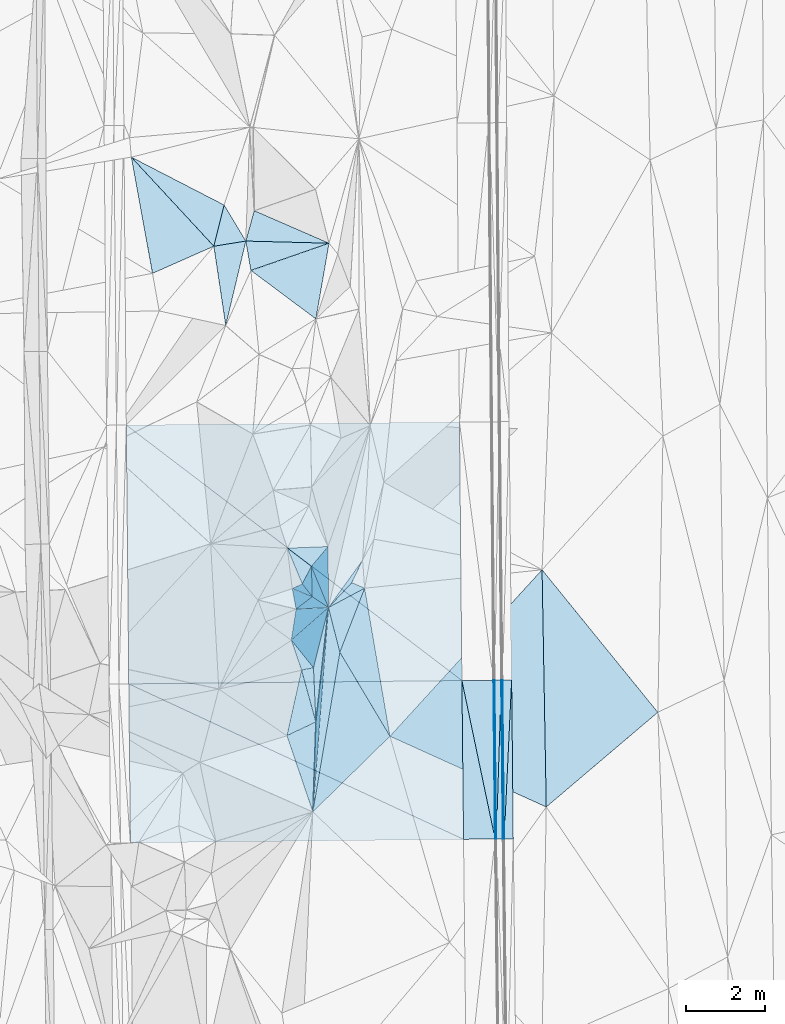
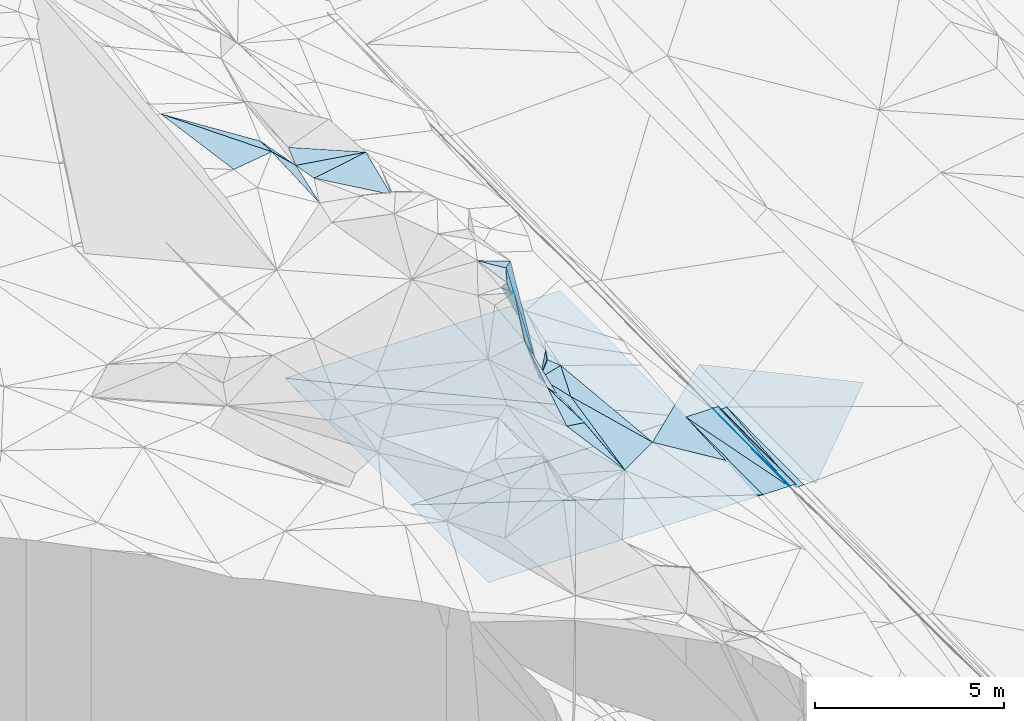
# One storey, part 20 of 275: 45 plates.
"""IFC2X3 building model written with IfcOpenShell, lengths in millimetres."""

from ifc_helpers import new_model, si_unit, frame, origin_with_axes, place, context, subcontext, project, spatial, polyline, outline, extrude, material, type_object, element, save


model = new_model("IFC2X3")

# Units and contexts
model_context = context("Model", 3, precision=1e-05, world=origin_with_axes())
body_context = subcontext(model_context, "Body", "Model", "MODEL_VIEW")
ifc_project = project(units=[si_unit("LENGTHUNIT", "METRE", prefix="MILLI"), si_unit("AREAUNIT", "SQUARE_METRE"), si_unit("VOLUMEUNIT", "CUBIC_METRE"), si_unit("MASSUNIT", "GRAM", prefix="KILO"), si_unit("TIMEUNIT", "SECOND"), si_unit("PLANEANGLEUNIT", "RADIAN"), si_unit("SOLIDANGLEUNIT", "STERADIAN"), si_unit("THERMODYNAMICTEMPERATUREUNIT", "DEGREE_CELSIUS"), si_unit("LUMINOUSINTENSITYUNIT", "LUMEN")], contexts=[model_context])

# Site, building, storey
site_placement = place(None, origin_with_axes())
site = spatial("IfcSite", under=ifc_project, at=site_placement, CompositionType="ELEMENT")
building_placement = place(site_placement, origin_with_axes())
building = spatial("IfcBuilding", under=site, at=building_placement, Name="Undefined", CompositionType="ELEMENT")
storey_placement = place(building_placement, origin_with_axes())
storey = spatial("IfcBuildingStorey", under=building, at=storey_placement, Name="Undefined", CompositionType="ELEMENT", Elevation=0.0)

# Plates
ifc_material = material()
plate_type_1 = type_object("IfcPlateType", PredefinedType="NOTDEFINED")
plate_1_placement = place(storey_placement, frame((-93784.4968107563, 18849.6755460461, 41301.2237487662), z_axis=(-0.970137003500872, -0.00498078457029193, -0.242506466353813), x_axis=(-0.0177606621139736, 0.998564026264901, 0.0505415109677563)))
element("IfcPlate", 1, at=plate_1_placement, inside=storey, type_object=plate_type_1, material=ifc_material, Name="00_PR", context=body_context, shape_type="SweptSolid", body=[
    extrude(outline(polyline([(0.0, 0.0), (4027.0263671875, 1.79716153070331e-09), (4021.033203125, 123.547782897949), (0.0, 0.0)])), frame((-8.85201319254618e-08, 2.18876761149539e-07, -0.5000001331573), z_axis=(0.0, 0.0, 1.0), x_axis=(1.0, 0.0, 0.0)), (0.0, 0.0, 1.0), 1.0),
])
plate_2_placement = place(storey_placement, frame((-93814.4923048652, 18849.1687863838, 41421.2237430247), z_axis=(-0.970134089902633, -0.00498014270644808, -0.242518134966055), x_axis=(-0.0103228671144175, 0.999731101343876, 0.0207644749584153)))
element("IfcPlate", 2, at=plate_2_placement, inside=storey, type_object=plate_type_1, material=ifc_material, Name="00_PR", context=body_context, shape_type="SweptSolid", body=[
    extrude(outline(polyline([(0.0, 0.0), (4022.83227539063, 7.20319803804159e-10), (-2.29475259780884, 123.671829223633), (0.0, 0.0)])), frame((-8.85201319254618e-08, 2.18876761149539e-07, -0.5000001331573), z_axis=(0.0, 0.0, 1.0), x_axis=(1.0, 0.0, 0.0)), (0.0, 0.0, 1.0), 1.0),
])
plate_type_2 = type_object("IfcPlateType", PredefinedType="NOTDEFINED")
plate_3_placement = place(storey_placement, frame((-94055.5346332526, 22868.9346980199, 41504.9772079253), z_axis=(-0.0201980559850125, 0.0205521822378433, -0.999584736948143), x_axis=(0.999750297888809, 0.00997524010701907, -0.0199959109831492)))
element("IfcPlate", 3, at=plate_3_placement, inside=storey, type_object=plate_type_2, material=ifc_material, Name="00_PR", context=body_context, shape_type="SweptSolid", body=[
    extrude(outline(polyline([(0.0, 0.0), (30.0061073303223, -1.96450855582953e-10), (33.074535369873, 4022.94555664063), (0.0, 0.0)])), frame((-8.85201319254618e-08, 2.18876761149539e-07, -0.5000001331573), z_axis=(0.0, 0.0, 1.0), x_axis=(1.0, 0.0, 0.0)), (0.0, 0.0, 1.0), 1.0),
])
plate_4_placement = place(storey_placement, frame((-93984.008453948, 18847.3689505921, 41420.8452099204), z_axis=(-0.0202120246646914, 0.0205520323630207, -0.99958445767464), x_axis=(-0.999743205174303, -0.0106622311091901, 0.0199960129922593)))
element("IfcPlate", 4, at=plate_4_placement, inside=storey, type_object=plate_type_2, material=ifc_material, Name="00_PR", context=body_context, shape_type="SweptSolid", body=[
    extrude(outline(polyline([(0.0, 0.0), (30.0059814453125, -3.63797880709171e-11), (30.3112621307373, 4022.96728515625), (0.0, 0.0)])), frame((-8.85201319254618e-08, 2.18876761149539e-07, -0.5000001331573), z_axis=(0.0, 0.0, 1.0), x_axis=(1.0, 0.0, 0.0)), (0.0, 0.0, 1.0), 1.0),
])
plate_type_3 = type_object("IfcPlateType", PredefinedType="NOTDEFINED")
plate_5_placement = place(storey_placement, frame((-94855.494476854, 22860.9414825007, 41520.9772072056), z_axis=(-0.0201980559850125, 0.0205521822378433, -0.999584736948143), x_axis=(0.999750153514179, 0.00998950710842837, -0.019996007004039)))
element("IfcPlate", 5, at=plate_5_placement, inside=storey, type_object=plate_type_3, material=ifc_material, Name="00_PR", context=body_context, shape_type="SweptSolid", body=[
    extrude(outline(polyline([(0.0, 0.0), (800.159790039063, 5.60248736292124e-09), (803.170959472656, 4022.96630859375), (0.0, 0.0)])), frame((-8.85201319254618e-08, 2.18876761149539e-07, -0.5000001331573), z_axis=(0.0, 0.0, 1.0), x_axis=(1.0, 0.0, 0.0)), (0.0, 0.0, 1.0), 1.0),
])
plate_6_placement = place(storey_placement, frame((-94014.0067291298, 18847.0490182657, 41421.445208476), z_axis=(-0.0202118903107055, 0.0205492764595215, -0.999584517050489), x_axis=(-0.999743257211094, -0.01065736010571, 0.0199960080148656)))
element("IfcPlate", 6, at=plate_6_placement, inside=storey, type_object=plate_type_3, material=ifc_material, Name="00_PR", context=body_context, shape_type="SweptSolid", body=[
    extrude(outline(polyline([(0.0, 0.0), (800.159729003906, -5.76255843043327e-09), (800.484436035156, 4023.50170898438), (0.0, 0.0)])), frame((-8.85201319254618e-08, 2.18876761149539e-07, -0.5000001331573), z_axis=(0.0, 0.0, 1.0), x_axis=(1.0, 0.0, 0.0)), (0.0, 0.0, 1.0), 1.0),
])
plate_type_4 = type_object("IfcPlateType", PredefinedType="NOTDEFINED")
plate_7_placement = place(storey_placement, frame((-93595.5306842776, 22873.5304274166, 41391.8773753473), z_axis=(0.0323782997089336, 0.021089755744167, -0.999253155066628), x_axis=(0.0103225611200021, -0.999731085997194, -0.0207653659441695)))
element("IfcPlate", 7, at=plate_7_placement, inside=storey, type_object=plate_type_4, material=ifc_material, Name="00_PR", context=body_context, shape_type="SweptSolid", body=[
    extrude(outline(polyline([(0.0, 0.0), (4022.65966796875, 1.94995664060116e-09), (4022.70458984375, 230.122406005859), (0.0, 0.0)])), frame((-8.85201319254618e-08, 2.18876761149539e-07, -0.5000001331573), z_axis=(0.0, 0.0, 1.0), x_axis=(1.0, 0.0, 0.0)), (0.0, 0.0, 1.0), 1.0),
])
plate_8_placement = place(storey_placement, frame((-93825.5247412299, 22871.5376246282, 41384.3773758265), z_axis=(0.0324024336787261, 0.021088608548602, -0.999252396985456), x_axis=(0.999431257214564, 0.0086596461168039, 0.0325909900378667)))
element("IfcPlate", 8, at=plate_8_placement, inside=storey, type_object=plate_type_4, material=ifc_material, Name="00_PR", context=body_context, shape_type="SweptSolid", body=[
    extrude(outline(polyline([(0.0, 0.0), (230.124954223633, -1.39698386192322e-09), (3.95540189743042, 4022.9287109375), (0.0, 0.0)])), frame((-8.85201319254618e-08, 2.18876761149539e-07, -0.5000001331573), z_axis=(0.0, 0.0, 1.0), x_axis=(1.0, 0.0, 0.0)), (0.0, 0.0, 1.0), 1.0),
])
plate_type_5 = type_object("IfcPlateType", PredefinedType="NOTDEFINED")
plate_9_placement = place(storey_placement, frame((-99178.4540863673, 23887.906368078, 44869.8037822111), z_axis=(-0.916078612303522, 0.0824970947312053, -0.392420954385674), x_axis=(0.395577747237267, 0.346284577128257, -0.850649891279481)))
element("IfcPlate", 9, at=plate_9_placement, inside=storey, type_object=plate_type_5, material=ifc_material, Name="00", context=body_context, shape_type="SweptSolid", body=[
    extrude(outline(polyline([(0.0, 0.0), (2379.35717773438, -1.52067514136434e-09), (1220.98095703125, 1204.41076660156), (0.0, 0.0)])), frame((-8.85201319254618e-08, 2.18876761149539e-07, -0.5000001331573), z_axis=(0.0, 0.0, 1.0), x_axis=(1.0, 0.0, 0.0)), (0.0, 0.0, 1.0), 1.0),
])
plate_type_6 = type_object("IfcPlateType", PredefinedType="NOTDEFINED")
plate_10_placement = place(storey_placement, frame((-99056.074387395, 24674.3936228062, 45909.820199391), z_axis=(-0.898417170212621, -0.252079903029262, -0.359586305017175), x_axis=(-0.179466824136462, 0.958095727034677, -0.223258229125526)))
element("IfcPlate", 10, at=plate_10_placement, inside=storey, type_object=plate_type_6, material=ifc_material, Name="00", context=body_context, shape_type="SweptSolid", body=[
    extrude(outline(polyline([(0.0, 0.0), (537.494201660156, 1.45519152283669e-11), (502.331024169922, 1244.85485839844), (0.0, 0.0)])), frame((-8.85201319254618e-08, 2.18876761149539e-07, -0.5000001331573), z_axis=(0.0, 0.0, 1.0), x_axis=(1.0, 0.0, 0.0)), (0.0, 0.0, 1.0), 1.0),
])
plate_type_7 = type_object("IfcPlateType", PredefinedType="NOTDEFINED")
plate_11_placement = place(storey_placement, frame((-103359.14779484, 29334.109961642, 41825.4522074339), z_axis=(-0.0201766175286049, 0.0205114375896883, -0.999586006821378), x_axis=(0.99976040560045, 0.00890123511554886, -0.0199974850178865)))
element("IfcPlate", 11, at=plate_11_placement, inside=storey, type_object=plate_type_7, material=ifc_material, Name="00_PR", context=body_context, shape_type="SweptSolid", body=[
    extrude(outline(polyline([(0.0, 0.0), (8443.8115234375, 2.20716174226254e-08), (8450.0849609375, 6550.0224609375), (0.0, 0.0)])), frame((-8.85201319254618e-08, 2.18876761149539e-07, -0.5000001331573), z_axis=(0.0, 0.0, 1.0), x_axis=(1.0, 0.0, 0.0)), (0.0, 0.0, 1.0), 1.0),
])
plate_type_8 = type_object("IfcPlateType", PredefinedType="NOTDEFINED")
plate_12_placement = place(storey_placement, frame((-94855.494476854, 22860.9414825007, 41520.9772072056), z_axis=(-0.0201984039825738, 0.0204828240091557, -0.999586153564147), x_axis=(-0.999750139086955, -0.00998889912159593, 0.0199970320285925)))
element("IfcPlate", 12, at=plate_12_placement, inside=storey, type_object=plate_type_8, material=ifc_material, Name="00_PR", context=body_context, shape_type="SweptSolid", body=[
    extrude(outline(polyline([(0.0, 0.0), (8443.953125, 3.58631950803101e-08), (8442.95703125, 6559.20751953125), (0.0, 0.0)])), frame((-8.85201319254618e-08, 2.18876761149539e-07, -0.5000001331573), z_axis=(0.0, 0.0, 1.0), x_axis=(1.0, 0.0, 0.0)), (0.0, 0.0, 1.0), 1.0),
])
plate_type_9 = type_object("IfcPlateType", PredefinedType="NOTDEFINED")
plate_13_placement = place(storey_placement, frame((-103297.337770174, 22776.5957172071, 41689.8312078601), z_axis=(-0.0201990417161664, 0.0205494152852743, -0.999584773916241), x_axis=(0.999750139087166, 0.00998889912134074, -0.0199970320181694)))
element("IfcPlate", 13, at=plate_13_placement, inside=storey, type_object=plate_type_9, material=ifc_material, Name="00_PR", context=body_context, shape_type="SweptSolid", body=[
    extrude(outline(polyline([(0.0, 0.0), (8443.953125, 3.58631950803101e-08), (8446.966796875, 4023.50048828125), (0.0, 0.0)])), frame((-8.85201319254618e-08, 2.18876761149539e-07, -0.5000001331573), z_axis=(0.0, 0.0, 1.0), x_axis=(1.0, 0.0, 0.0)), (0.0, 0.0, 1.0), 1.0),
])
plate_type_10 = type_object("IfcPlateType", PredefinedType="NOTDEFINED")
plate_14_placement = place(storey_placement, frame((-94813.9610234071, 18838.5214139636, 41437.445207875), z_axis=(-0.0202125242649129, 0.0205203913559405, -0.999585097628731), x_axis=(-0.999743242543018, -0.0106569761148438, 0.0199969460083529)))
element("IfcPlate", 14, at=plate_14_placement, inside=storey, type_object=plate_type_10, material=ifc_material, Name="00_PR", context=body_context, shape_type="SweptSolid", body=[
    extrude(outline(polyline([(0.0, 0.0), (8444.0390625, 5.16338332090527e-08), (8444.27734375, 4029.14208984375), (0.0, 0.0)])), frame((-8.85201319254618e-08, 2.18876761149539e-07, -0.5000001331573), z_axis=(0.0, 0.0, 1.0), x_axis=(1.0, 0.0, 0.0)), (0.0, 0.0, 1.0), 1.0),
])
plate_type_11 = type_object("IfcPlateType", PredefinedType="NOTDEFINED")
plate_15_placement = place(storey_placement, frame((-93983.9984525087, 18847.3690562516, 41420.845109956), z_axis=(-0.00020739077411613, 0.0207628493825329, -0.999784407297186), x_axis=(-0.0103228671144175, 0.999731101343876, 0.0207644749584153)))
element("IfcPlate", 15, at=plate_15_placement, inside=storey, type_object=plate_type_11, material=ifc_material, Name="00_PR", context=body_context, shape_type="SweptSolid", body=[
    extrude(outline(polyline([(0.0, 0.0), (4022.94677734375, 5.66069502383471e-09), (4022.8896484375, 169.999969482422), (0.0, 0.0)])), frame((-8.85201319254618e-08, 2.18876761149539e-07, -0.5000001331573), z_axis=(0.0, 0.0, 1.0), x_axis=(1.0, 0.0, 0.0)), (0.0, 0.0, 1.0), 1.0),
])
plate_16_placement = place(storey_placement, frame((-93855.5345087736, 22870.9321076468, 41504.3771097677), z_axis=(-0.000221397235770263, 0.0207632958266137, -0.999784395022087), x_axis=(0.0103228671152748, -0.999731101343363, -0.0207644749826731)))
element("IfcPlate", 16, at=plate_16_placement, inside=storey, type_object=plate_type_11, material=ifc_material, Name="00_PR", context=body_context, shape_type="SweptSolid", body=[
    extrude(outline(polyline([(0.0, 0.0), (4022.83227539063, 7.20319803804159e-10), (4022.88940429688, 170.000762939453), (0.0, 0.0)])), frame((-8.85201319254618e-08, 2.18876761149539e-07, -0.5000001331573), z_axis=(0.0, 0.0, 1.0), x_axis=(1.0, 0.0, 0.0)), (0.0, 0.0, 1.0), 1.0),
])
plate_type_12 = type_object("IfcPlateType", PredefinedType="NOTDEFINED")
plate_17_placement = place(storey_placement, frame((-103231.84165598, 36123.560950308, 46199.5674940076), z_axis=(-0.460134805248132, -0.200214797909722, -0.864979766062324), x_axis=(0.834402874416335, -0.43043242945225, -0.344237950902559)))
element("IfcPlate", 17, at=plate_17_placement, inside=storey, type_object=plate_type_12, material=ifc_material, Name="00", context=body_context, shape_type="SweptSolid", body=[
    extrude(outline(polyline([(0.0, 0.0), (2817.818359375, 2.08092387765646e-09), (2919.59912109375, 1136.7236328125), (0.0, 0.0)])), frame((-8.85201319254618e-08, 2.18876761149539e-07, -0.5000001331573), z_axis=(0.0, 0.0, 1.0), x_axis=(1.0, 0.0, 0.0)), (0.0, 0.0, 1.0), 1.0),
])
plate_type_13 = type_object("IfcPlateType", PredefinedType="NOTDEFINED")
plate_18_placement = place(storey_placement, frame((-98222.167742163, 33943.0561995992, 44529.5061168472), z_axis=(-0.127966120455224, 0.0892805977110064, -0.987751814418989), x_axis=(-0.99109239693606, 0.025528535843689, 0.130706367837278)))
element("IfcPlate", 18, at=plate_18_placement, inside=storey, type_object=plate_type_13, material=ifc_material, Name="00", context=body_context, shape_type="SweptSolid", body=[
    extrude(outline(polyline([(0.0, 0.0), (2126.90478515625, -1.35041773319244e-08), (1941.03662109375, 777.931213378906), (0.0, 0.0)])), frame((-8.85201319254618e-08, 2.18876761149539e-07, -0.5000001331573), z_axis=(0.0, 0.0, 1.0), x_axis=(1.0, 0.0, 0.0)), (0.0, 0.0, 1.0), 1.0),
])
plate_type_14 = type_object("IfcPlateType", PredefinedType="NOTDEFINED")
plate_19_placement = place(storey_placement, frame((-100202.436654351, 33253.4107453727, 44799.5043392136), z_axis=(-0.131039394313345, -0.0118326414007659, -0.991306544785957), x_axis=(-0.16916990717031, 0.985529913986078, 0.0105986389023447)))
element("IfcPlate", 19, at=plate_19_placement, inside=storey, type_object=plate_type_14, material=ifc_material, Name="00", context=body_context, shape_type="SweptSolid", body=[
    extrude(outline(polyline([(0.0, 0.0), (754.813903808594, 2.77941580861807e-09), (341.753112792969, 2086.40966796875), (0.0, 0.0)])), frame((-8.85201319254618e-08, 2.18876761149539e-07, -0.5000001331573), z_axis=(0.0, 0.0, 1.0), x_axis=(1.0, 0.0, 0.0)), (0.0, 0.0, 1.0), 1.0),
])
plate_type_15 = type_object("IfcPlateType", PredefinedType="NOTDEFINED")
plate_20_placement = place(storey_placement, frame((-98918.7874253092, 23127.9579778307, 43729.5713265195), z_axis=(-0.487509719123345, 0.16527568985682, -0.857332036087903), x_axis=(0.252012967213494, -0.913492917982273, -0.319405937879188)))
element("IfcPlate", 20, at=plate_20_placement, inside=storey, type_object=plate_type_15, material=ifc_material, Name="00", context=body_context, shape_type="SweptSolid", body=[
    extrude(outline(polyline([(0.0, 0.0), (1440.17358398438, -5.23868948221207e-10), (1459.61572265625, 882.395629882813), (0.0, 0.0)])), frame((-8.85201319254618e-08, 2.18876761149539e-07, -0.5000001331573), z_axis=(0.0, 0.0, 1.0), x_axis=(1.0, 0.0, 0.0)), (0.0, 0.0, 1.0), 1.0),
])
plate_type_16 = type_object("IfcPlateType", PredefinedType="NOTDEFINED")
plate_21_placement = place(storey_placement, frame((-97371.5519507725, 25910.7409446342, 42699.6099998164), z_axis=(0.45863771018458, -0.425795357895936, -0.779967796765301), x_axis=(-0.421102895383042, -0.877056538187655, 0.231179973878159)))
element("IfcPlate", 21, at=plate_21_placement, inside=storey, type_object=plate_type_16, material=ifc_material, Name="00", context=body_context, shape_type="SweptSolid", body=[
    extrude(outline(polyline([(0.0, 0.0), (648.845153808594, -6.98491930961609e-10), (1449.72961425781, 325.246124267578), (0.0, 0.0)])), frame((-8.85201319254618e-08, 2.18876761149539e-07, -0.5000001331573), z_axis=(0.0, 0.0, 1.0), x_axis=(1.0, 0.0, 0.0)), (0.0, 0.0, 1.0), 1.0),
])
plate_type_17 = type_object("IfcPlateType", PredefinedType="NOTDEFINED")
plate_22_placement = place(storey_placement, frame((-98647.2414390695, 24986.6978692043, 44669.8362120271), z_axis=(-0.797216414226662, 0.507099449205218, -0.327560891290991), x_axis=(-0.212150741114206, 0.272654654918338, 0.93843033955433)))
element("IfcPlate", 22, at=plate_22_placement, inside=storey, type_object=plate_type_17, material=ifc_material, Name="00", context=body_context, shape_type="SweptSolid", body=[
    extrude(outline(polyline([(0.0, 0.0), (1193.48229980469, -3.26690496876836e-09), (1377.31408691406, 478.336578369141), (0.0, 0.0)])), frame((-8.85201319254618e-08, 2.18876761149539e-07, -0.5000001331573), z_axis=(0.0, 0.0, 1.0), x_axis=(1.0, 0.0, 0.0)), (0.0, 0.0, 1.0), 1.0),
])
plate_type_18 = type_object("IfcPlateType", PredefinedType="NOTDEFINED")
plate_23_placement = place(storey_placement, frame((-98237.1711590442, 24712.0676320033, 42845.8531790374), z_axis=(-0.791795103453675, 0.535578000935874, -0.293626836410295), x_axis=(-0.13229472322, 0.318940236081365, 0.938496261056221)))
element("IfcPlate", 23, at=plate_23_placement, inside=storey, type_object=plate_type_18, material=ifc_material, Name="00", context=body_context, shape_type="SweptSolid", body=[
    extrude(outline(polyline([(0.0, 0.0), (3264.79711914063, 8.63656168803573e-09), (3163.13403320313, 685.758422851563), (0.0, 0.0)])), frame((-8.85201319254618e-08, 2.18876761149539e-07, -0.5000001331573), z_axis=(0.0, 0.0, 1.0), x_axis=(1.0, 0.0, 0.0)), (0.0, 0.0, 1.0), 1.0),
])
plate_type_19 = type_object("IfcPlateType", PredefinedType="NOTDEFINED")
plate_24_placement = place(storey_placement, frame((-98632.0864719169, 19533.9249565625, 43149.5555355782), z_axis=(-0.453859039117308, 0.0620086676047972, -0.88891332409487), x_axis=(-0.313440020163929, 0.922712938880295, 0.224401840862603)))
element("IfcPlate", 24, at=plate_24_placement, inside=storey, type_object=plate_type_19, material=ifc_material, Name="00", context=body_context, shape_type="SweptSolid", body=[
    extrude(outline(polyline([(0.0, 0.0), (2094.45703125, -1.48429535329342e-09), (2105.32861328125, 882.542785644531), (0.0, 0.0)])), frame((-8.85201319254618e-08, 2.18876761149539e-07, -0.5000001331573), z_axis=(0.0, 0.0, 1.0), x_axis=(1.0, 0.0, 0.0)), (0.0, 0.0, 1.0), 1.0),
])
plate_type_20 = type_object("IfcPlateType", PredefinedType="NOTDEFINED")
plate_25_placement = place(storey_placement, frame((-98237.2413554322, 24711.824882757, 42845.8207512426), z_axis=(-0.932192925193293, 0.0500813906744574, -0.358480410242574), x_axis=(-0.0759507628610222, -0.995397487095036, 0.0584407760533487)))
element("IfcPlate", 25, at=plate_25_placement, inside=storey, type_object=plate_type_20, material=ifc_material, Name="00", context=body_context, shape_type="SweptSolid", body=[
    extrude(outline(polyline([(0.0, 0.0), (5201.84765625, 3.34694050252438e-09), (2935.16186523438, 270.972625732422), (0.0, 0.0)])), frame((-8.85201319254618e-08, 2.18876761149539e-07, -0.5000001331573), z_axis=(0.0, 0.0, 1.0), x_axis=(1.0, 0.0, 0.0)), (0.0, 0.0, 1.0), 1.0),
])
plate_type_21 = type_object("IfcPlateType", PredefinedType="NOTDEFINED")
plate_26_placement = place(storey_placement, frame((-100330.409802138, 33997.2645746784, 44807.6424641649), z_axis=(-0.693581315961245, -0.0875427567997847, -0.715039316318593), x_axis=(-0.706105530044613, -0.113989706499513, 0.698871466904016)))
element("IfcPlate", 26, at=plate_26_placement, inside=storey, type_object=plate_type_21, material=ifc_material, Name="00", context=body_context, shape_type="SweptSolid", body=[
    extrude(outline(polyline([(0.0, 0.0), (1147.56433105469, 5.16592990607023e-09), (579.404541015625, 989.795104980469), (0.0, 0.0)])), frame((-8.85201319254618e-08, 2.18876761149539e-07, -0.5000001331573), z_axis=(0.0, 0.0, 1.0), x_axis=(1.0, 0.0, 0.0)), (0.0, 0.0, 1.0), 1.0),
])
plate_type_22 = type_object("IfcPlateType", PredefinedType="NOTDEFINED")
plate_27_placement = place(storey_placement, frame((-98236.9752747191, 24711.9902859095, 42845.5831292813), z_axis=(-0.399865023791949, 0.380841028008734, -0.833707427178813), x_axis=(0.684588276370494, 0.728915275328826, 0.00462744512421722)))
element("IfcPlate", 27, at=plate_27_placement, inside=storey, type_object=plate_type_22, material=ifc_material, Name="00", context=body_context, shape_type="SweptSolid", body=[
    extrude(outline(polyline([(0.0, 0.0), (864.407897949219, -4.33647073805332e-09), (983.032470703125, 399.409820556641), (0.0, 0.0)])), frame((-8.85201319254618e-08, 2.18876761149539e-07, -0.5000001331573), z_axis=(0.0, 0.0, 1.0), x_axis=(1.0, 0.0, 0.0)), (0.0, 0.0, 1.0), 1.0),
])
plate_type_23 = type_object("IfcPlateType", PredefinedType="NOTDEFINED")
plate_28_placement = place(storey_placement, frame((-98554.9228438763, 32024.6938398143, 44439.5078167907), z_axis=(-0.159954987911786, 0.0739253215508438, -0.984352299065606), x_axis=(-0.789584541829697, 0.588888063661689, 0.172531445772574)))
element("IfcPlate", 28, at=plate_28_placement, inside=storey, type_object=plate_type_23, material=ifc_material, Name="00", context=body_context, shape_type="SweptSolid", body=[
    extrude(outline(polyline([(0.0, 0.0), (2086.576171875, -6.19911588728428e-09), (882.498352050781, 1737.84252929688), (0.0, 0.0)])), frame((-8.85201319254618e-08, 2.18876761149539e-07, -0.5000001331573), z_axis=(0.0, 0.0, 1.0), x_axis=(1.0, 0.0, 0.0)), (0.0, 0.0, 1.0), 1.0),
])
plate_type_24 = type_object("IfcPlateType", PredefinedType="NOTDEFINED")
plate_29_placement = place(storey_placement, frame((-98555.9659121345, 21812.3057813492, 43269.6584291082), z_axis=(-0.729327945829034, 0.037652021245876, -0.683127420565814), x_axis=(-0.25201296721256, 0.913492917983315, 0.319405937876944)))
element("IfcPlate", 29, at=plate_29_placement, inside=storey, type_object=plate_type_24, material=ifc_material, Name="00", context=body_context, shape_type="SweptSolid", body=[
    extrude(outline(polyline([(0.0, 0.0), (1440.17358398438, -5.23868948221207e-10), (1314.00830078125, 425.890014648438), (0.0, 0.0)])), frame((-8.85201319254618e-08, 2.18876761149539e-07, -0.5000001331573), z_axis=(0.0, 0.0, 1.0), x_axis=(1.0, 0.0, 0.0)), (0.0, 0.0, 1.0), 1.0),
])
plate_type_25 = type_object("IfcPlateType", PredefinedType="NOTDEFINED")
plate_30_placement = place(storey_placement, frame((-98616.1835184362, 23185.4328626341, 43409.7411600023), z_axis=(-0.652094902824363, 0.553890479266516, -0.517665504634406), x_axis=(-0.681442283419081, -0.128956680117776, 0.720421119222355)))
element("IfcPlate", 30, at=plate_30_placement, inside=storey, type_object=plate_type_25, material=ifc_material, Name="00", context=body_context, shape_type="SweptSolid", body=[
    extrude(outline(polyline([(0.0, 0.0), (444.184631347656, -3.92901711165905e-10), (1344.2607421875, 1065.06481933594), (0.0, 0.0)])), frame((-8.85201319254618e-08, 2.18876761149539e-07, -0.5000001331573), z_axis=(0.0, 0.0, 1.0), x_axis=(1.0, 0.0, 0.0)), (0.0, 0.0, 1.0), 1.0),
])
plate_type_26 = type_object("IfcPlateType", PredefinedType="NOTDEFINED")
plate_31_placement = place(storey_placement, frame((-99056.060631464, 24674.7377162969, 45909.886286759), z_axis=(-0.870710738329876, 0.436069194982892, -0.227390561246537), x_axis=(0.258169717105632, 0.0117538191684377, -0.966028076664728)))
element("IfcPlate", 31, at=plate_31_placement, inside=storey, type_object=plate_type_26, material=ifc_material, Name="00", context=body_context, shape_type="SweptSolid", body=[
    extrude(outline(polyline([(0.0, 0.0), (3171.75048828125, -2.47382558882236e-10), (963.83056640625, 886.809265136719), (0.0, 0.0)])), frame((-8.85201319254618e-08, 2.18876761149539e-07, -0.5000001331573), z_axis=(0.0, 0.0, 1.0), x_axis=(1.0, 0.0, 0.0)), (0.0, 0.0, 1.0), 1.0),
])
plate_type_27 = type_object("IfcPlateType", PredefinedType="NOTDEFINED")
plate_32_placement = place(storey_placement, frame((-101140.718442417, 33866.5391029343, 45609.6491760119), z_axis=(-0.707756208859499, 0.0825659148089836, -0.701615292402172), x_axis=(0.706105530044742, 0.113989706501115, -0.698871466903624)))
element("IfcPlate", 32, at=plate_32_placement, inside=storey, type_object=plate_type_27, material=ifc_material, Name="00", context=body_context, shape_type="SweptSolid", body=[
    extrude(outline(polyline([(0.0, 0.0), (1147.56433105469, 5.16592990607023e-09), (360.915710449219, 2070.60131835938), (0.0, 0.0)])), frame((-8.85201319254618e-08, 2.18876761149539e-07, -0.5000001331573), z_axis=(0.0, 0.0, 1.0), x_axis=(1.0, 0.0, 0.0)), (0.0, 0.0, 1.0), 1.0),
])
plate_type_28 = type_object("IfcPlateType", PredefinedType="NOTDEFINED")
plate_33_placement = place(storey_placement, frame((-98631.9669450907, 19533.8735142871, 43149.5120605425), z_axis=(-0.214606251612307, -0.040917848388992, -0.97584316693418), x_axis=(0.0759507624557861, 0.995397487130712, -0.0584407759723316)))
element("IfcPlate", 33, at=plate_33_placement, inside=storey, type_object=plate_type_28, material=ifc_material, Name="00", context=body_context, shape_type="SweptSolid", body=[
    extrude(outline(polyline([(0.0, 0.0), (5201.84765625, 3.34694050252438e-09), (4096.94482421875, 382.7421875), (0.0, 0.0)])), frame((-8.85201319254618e-08, 2.18876761149539e-07, -0.5000001331573), z_axis=(0.0, 0.0, 1.0), x_axis=(1.0, 0.0, 0.0)), (0.0, 0.0, 1.0), 1.0),
])
plate_type_29 = type_object("IfcPlateType", PredefinedType="NOTDEFINED")
plate_34_placement = place(storey_placement, frame((-98246.5057638177, 26256.8162114432, 45689.5346658935), z_axis=(-0.347273487254605, -0.115263805890976, -0.930653200768983), x_axis=(-0.609241445074735, -0.726716872251596, 0.317344370027429)))
element("IfcPlate", 34, at=plate_34_placement, inside=storey, type_object=plate_type_29, material=ifc_material, Name="00", context=body_context, shape_type="SweptSolid", body=[
    extrude(outline(polyline([(0.0, 0.0), (693.253173828125, 2.47382558882236e-10), (781.821105957031, 779.009460449219), (0.0, 0.0)])), frame((-8.85201319254618e-08, 2.18876761149539e-07, -0.5000001331573), z_axis=(0.0, 0.0, 1.0), x_axis=(1.0, 0.0, 0.0)), (0.0, 0.0, 1.0), 1.0),
])
plate_type_30 = type_object("IfcPlateType", PredefinedType="NOTDEFINED")
plate_35_placement = place(storey_placement, frame((-99278.0302868638, 26216.397798719, 46079.5215414386), z_axis=(-0.0494387774192643, 0.286172977897456, -0.956901684609548), x_axis=(0.777159503028195, -0.590769246808689, -0.216828973797468)))
element("IfcPlate", 35, at=plate_35_placement, inside=storey, type_object=plate_type_30, material=ifc_material, Name="00", context=body_context, shape_type="SweptSolid", body=[
    extrude(outline(polyline([(0.0, 0.0), (784.028076171875, 1.45519152283669e-10), (890.911987304688, 501.174438476563), (0.0, 0.0)])), frame((-8.85201319254618e-08, 2.18876761149539e-07, -0.5000001331573), z_axis=(0.0, 0.0, 1.0), x_axis=(1.0, 0.0, 0.0)), (0.0, 0.0, 1.0), 1.0),
])
plate_type_31 = type_object("IfcPlateType", PredefinedType="NOTDEFINED")
plate_36_placement = place(storey_placement, frame((-98669.1324307026, 25753.2707449159, 45909.8712183706), z_axis=(-0.883445498138699, 0.391398765030219, -0.25754816743919), x_axis=(0.132294723227501, -0.318940236080854, -0.938496261055337)))
element("IfcPlate", 36, at=plate_36_placement, inside=storey, type_object=plate_type_31, material=ifc_material, Name="00", context=body_context, shape_type="SweptSolid", body=[
    extrude(outline(polyline([(0.0, 0.0), (3264.79711914063, 8.63656168803573e-09), (1411.13513183594, 366.739288330078), (0.0, 0.0)])), frame((-8.85201319254618e-08, 2.18876761149539e-07, -0.5000001331573), z_axis=(0.0, 0.0, 1.0), x_axis=(1.0, 0.0, 0.0)), (0.0, 0.0, 1.0), 1.0),
])
plate_type_32 = type_object("IfcPlateType", PredefinedType="NOTDEFINED")
plate_37_placement = place(storey_placement, frame((-98647.0482805682, 24986.8675134216, 44669.8305902621), z_axis=(-0.410900110995178, 0.846387992332154, -0.338804464581115), x_axis=(-0.405704559300745, 0.163043325049725, 0.899344586195591)))
element("IfcPlate", 37, at=plate_37_placement, inside=storey, type_object=plate_type_32, material=ifc_material, Name="00", context=body_context, shape_type="SweptSolid", body=[
    extrude(outline(polyline([(0.0, 0.0), (1245.35131835938, 3.18686943501234e-09), (1163.04528808594, 267.816558837891), (0.0, 0.0)])), frame((-8.85201319254618e-08, 2.18876761149539e-07, -0.5000001331573), z_axis=(0.0, 0.0, 1.0), x_axis=(1.0, 0.0, 0.0)), (0.0, 0.0, 1.0), 1.0),
])
plate_type_33 = type_object("IfcPlateType", PredefinedType="NOTDEFINED")
plate_38_placement = place(storey_placement, frame((-98647.3115936972, 24986.5665393331, 44669.8762032559), z_axis=(-0.93752556472596, 0.244439748585656, -0.247578320530394), x_axis=(0.217013722244598, -0.145345851073653, -0.96528732920992)))
element("IfcPlate", 38, at=plate_38_placement, inside=storey, type_object=plate_type_33, material=ifc_material, Name="00", context=body_context, shape_type="SweptSolid", body=[
    extrude(outline(polyline([(0.0, 0.0), (1889.5927734375, -4.9049049266614e-09), (-1240.33068847656, 513.400146484375), (0.0, 0.0)])), frame((-8.85201319254618e-08, 2.18876761149539e-07, -0.5000001331573), z_axis=(0.0, 0.0, 1.0), x_axis=(1.0, 0.0, 0.0)), (0.0, 0.0, 1.0), 1.0),
])
plate_type_34 = type_object("IfcPlateType", PredefinedType="NOTDEFINED")
plate_39_placement = place(storey_placement, frame((-98237.2001830621, 24711.8080519364, 42845.7366070769), z_axis=(-0.849848813594838, 0.0164176116193477, -0.526770781327289), x_axis=(-0.10816301585905, -0.983671563021752, 0.14384372806146)))
element("IfcPlate", 39, at=plate_39_placement, inside=storey, type_object=plate_type_34, material=ifc_material, Name="00", context=body_context, shape_type="SweptSolid", body=[
    extrude(outline(polyline([(0.0, 0.0), (2947.64331054688, 1.67347025126219e-09), (1623.84680175781, 394.414398193359), (0.0, 0.0)])), frame((-8.85201319254618e-08, 2.18876761149539e-07, -0.5000001331573), z_axis=(0.0, 0.0, 1.0), x_axis=(1.0, 0.0, 0.0)), (0.0, 0.0, 1.0), 1.0),
])
plate_type_35 = type_object("IfcPlateType", PredefinedType="NOTDEFINED")
plate_40_placement = place(storey_placement, frame((-96679.1295713607, 21450.20378815, 42199.5403996738), z_axis=(-0.391997421662636, 0.0383364726687121, -0.91916719712638), x_axis=(-0.496301539484801, 0.832455876466631, 0.246377749890669)))
element("IfcPlate", 40, at=plate_40_placement, inside=storey, type_object=plate_type_35, material=ifc_material, Name="00", context=body_context, shape_type="SweptSolid", body=[
    extrude(outline(polyline([(0.0, 0.0), (2557.04907226563, -2.99769453704357e-09), (3546.78369140625, 1444.37719726563), (0.0, 0.0)])), frame((-8.85201319254618e-08, 2.18876761149539e-07, -0.5000001331573), z_axis=(0.0, 0.0, 1.0), x_axis=(1.0, 0.0, 0.0)), (0.0, 0.0, 1.0), 1.0),
])
plate_type_36 = type_object("IfcPlateType", PredefinedType="NOTDEFINED")
plate_41_placement = place(storey_placement, frame((-97320.4813773768, 25201.1048215471, 42629.5114466766), z_axis=(-0.209198191348087, -0.0395220596109075, -0.977074267157211), x_axis=(-0.358449318242263, -0.926534899882193, 0.11422418987216)))
element("IfcPlate", 41, at=plate_41_placement, inside=storey, type_object=plate_type_36, material=ifc_material, Name="00", context=body_context, shape_type="SweptSolid", body=[
    extrude(outline(polyline([(0.0, 0.0), (1750.94262695313, -1.90630089491606e-09), (806.531311035156, 689.484069824219), (0.0, 0.0)])), frame((-8.85201319254618e-08, 2.18876761149539e-07, -0.5000001331573), z_axis=(0.0, 0.0, 1.0), x_axis=(1.0, 0.0, 0.0)), (0.0, 0.0, 1.0), 1.0),
])
plate_type_37 = type_object("IfcPlateType", PredefinedType="NOTDEFINED")
plate_42_placement = place(storey_placement, frame((-101140.49032296, 33866.5077723381, 45609.5161599388), z_axis=(-0.251516256937836, 0.0199054753725382, -0.967648357899797), x_axis=(-0.891449559995152, -0.394105728721323, 0.223603122906377)))
element("IfcPlate", 42, at=plate_42_placement, inside=storey, type_object=plate_type_37, material=ifc_material, Name="00", context=body_context, shape_type="SweptSolid", body=[
    extrude(outline(polyline([(0.0, 0.0), (1744.16174316406, -9.42964106798172e-09), (1106.60607910156, 2931.14697265625), (0.0, 0.0)])), frame((-8.85201319254618e-08, 2.18876761149539e-07, -0.5000001331573), z_axis=(0.0, 0.0, 1.0), x_axis=(1.0, 0.0, 0.0)), (0.0, 0.0, 1.0), 1.0),
])
plate_type_38 = type_object("IfcPlateType", PredefinedType="NOTDEFINED")
plate_43_placement = place(storey_placement, frame((-96679.1536242232, 21450.1863044309, 42199.5510140124), z_axis=(-0.440108542102334, 0.00337010111013317, -0.897938257112963), x_axis=(-0.674281609435172, -0.661632599314209, 0.328003985802364)))
element("IfcPlate", 43, at=plate_43_placement, inside=storey, type_object=plate_type_38, material=ifc_material, Name="00", context=body_context, shape_type="SweptSolid", body=[
    extrude(outline(polyline([(0.0, 0.0), (2896.30615234375, -1.38243194669485e-08), (-346.020050048828, 2533.529296875), (0.0, 0.0)])), frame((-8.85201319254618e-08, 2.18876761149539e-07, -0.5000001331573), z_axis=(0.0, 0.0, 1.0), x_axis=(1.0, 0.0, 0.0)), (0.0, 0.0, 1.0), 1.0),
])
plate_type_39 = type_object("IfcPlateType", PredefinedType="NOTDEFINED")
plate_44_placement = place(storey_placement, frame((-92717.8040701378, 19657.7508325008, 40584.5151159465), z_axis=(0.240739323031051, 0.040560480367195, -0.96974193772309), x_axis=(-0.0176688015456144, 0.999144012367575, 0.0374039570361778)))
element("IfcPlate", 44, at=plate_44_placement, inside=storey, type_object=plate_type_39, material=ifc_material, Name="00", context=body_context, shape_type="SweptSolid", body=[
    extrude(outline(polyline([(0.0, 0.0), (6015.40625, -3.49245965480804e-09), (2376.69799804688, 2955.86474609375), (0.0, 0.0)])), frame((-8.85201319254618e-08, 2.18876761149539e-07, -0.5000001331573), z_axis=(0.0, 0.0, 1.0), x_axis=(1.0, 0.0, 0.0)), (0.0, 0.0, 1.0), 1.0),
])
plate_type_40 = type_object("IfcPlateType", PredefinedType="NOTDEFINED")
plate_45_placement = place(storey_placement, frame((-92824.3926510196, 25668.0019997585, 40809.5349666559), z_axis=(-0.366374679344185, 0.0283378738439634, -0.930035783849981), x_axis=(0.0176688015648657, -0.999144012368003, -0.0374039570156699)))
element("IfcPlate", 45, at=plate_45_placement, inside=storey, type_object=plate_type_40, material=ifc_material, Name="00", context=body_context, shape_type="SweptSolid", body=[
    extrude(outline(polyline([(0.0, 0.0), (6015.40625, -3.49245965480804e-09), (4094.09301757813, 4221.287109375), (0.0, 0.0)])), frame((-8.85201319254618e-08, 2.18876761149539e-07, -0.5000001331573), z_axis=(0.0, 0.0, 1.0), x_axis=(1.0, 0.0, 0.0)), (0.0, 0.0, 1.0), 1.0),
])

save(model, "model.ifc")
